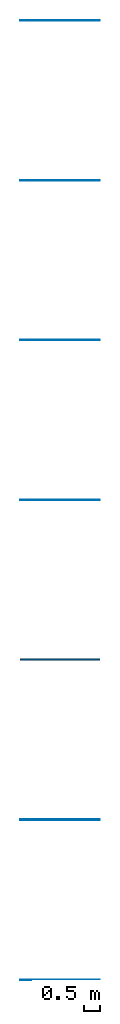
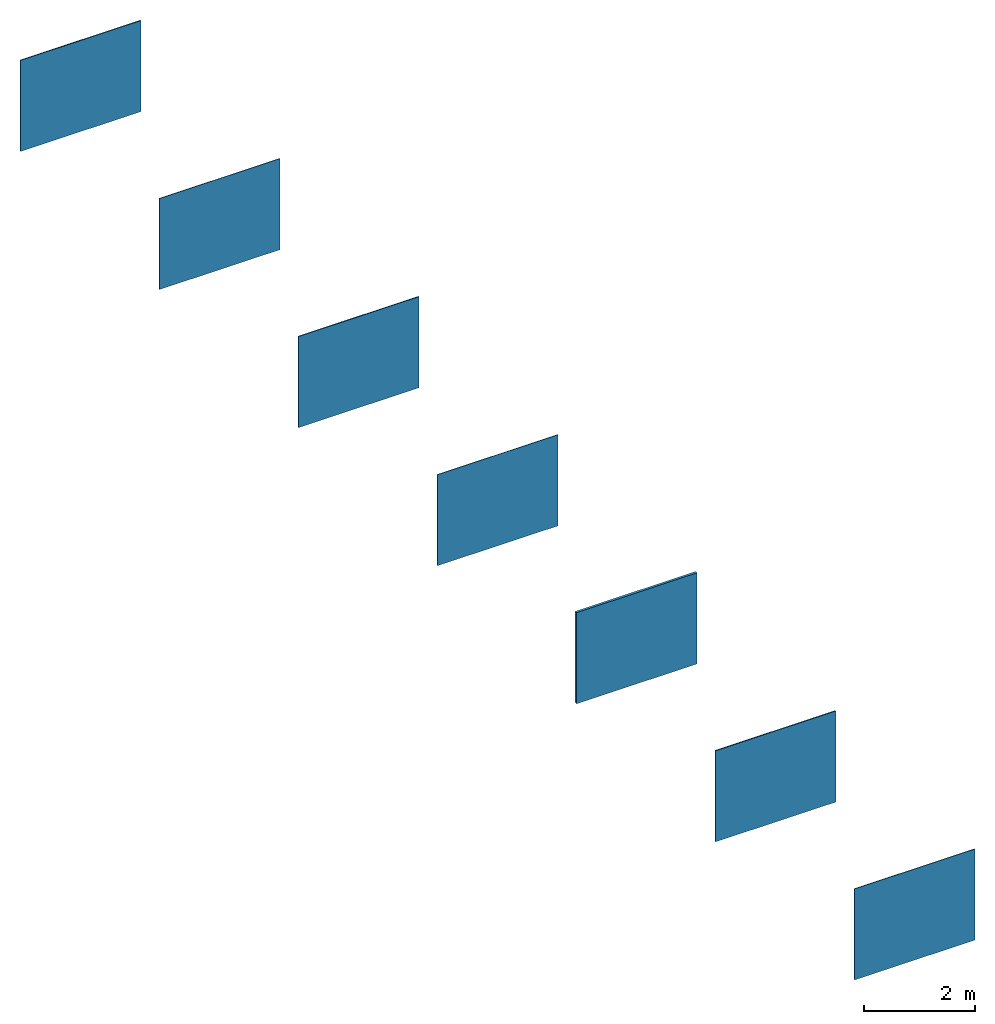
# Not in any storey: 7 walls.
"""IFC2X3 building model written with IfcOpenShell, lengths in millimetres."""

from ifc_helpers import new_model, si_unit, frame, frame_2d, origin, origin_with_axes, origin_2d, place, context, project, spatial, rectangle, extrude, material, layer, layer_set, layer_usage, type_object, element, save


model = new_model("IFC2X3")

# Units and contexts
model_context = context("Model", 3, precision=1e-05, world=origin())
plan_context = context("Plan", 2, precision=1e-05, world=origin_2d())
ifc_project = project(units=[si_unit("LENGTHUNIT", "METRE", prefix="MILLI"), si_unit("AREAUNIT", "SQUARE_METRE"), si_unit("VOLUMEUNIT", "CUBIC_METRE"), si_unit("SOLIDANGLEUNIT", "STERADIAN"), si_unit("PLANEANGLEUNIT", "RADIAN"), si_unit("MASSUNIT", "GRAM"), si_unit("TIMEUNIT", "SECOND"), si_unit("THERMODYNAMICTEMPERATUREUNIT", "DEGREE_CELSIUS"), si_unit("LUMINOUSINTENSITYUNIT", "LUMEN")], contexts=[model_context, plan_context])

# Site, building
site_placement = place(None, frame((0.0, 0.0, 0.0), z_axis=(0.0, 1.0, 0.0), x_axis=(0.0, 0.0, 1.0)))
site = spatial("IfcSite", under=ifc_project, at=site_placement, CompositionType="ELEMENT")
building_placement = place(site_placement, frame((0.0, 0.0, 0.0), z_axis=(0.0, 1.0, 0.0), x_axis=(0.0, 0.0, 1.0)))
building = spatial("IfcBuilding", under=site, at=building_placement, Name="Default building", CompositionType="ELEMENT")

# Walls
ifc_material_1 = material()
ifc_layer_1 = layer(ifc_material_1, 14.0, ventilated=False)
ifc_layer_set_1 = layer_set([ifc_layer_1])
ifc_layer_usage_1 = layer_usage(ifc_layer_set_1, "AXIS2", "POSITIVE", 0.0)
wall_type_1 = type_object("IfcWallType", PredefinedType="STANDARD", material=ifc_layer_set_1)
wall_1_placement = place(None, origin())
element("IfcWallStandardCase", 1, at=wall_1_placement, inside=building, type_object=wall_type_1, material=ifc_layer_usage_1, context=model_context, shape_type="SweptSolid", body=[
    extrude(rectangle(XDim=2500.0, YDim=14.0, at=frame_2d((1250.0, 7.0))), origin_with_axes(), (0.0, 0.0, 1.0), 2000.0),
])
ifc_material_2 = material()
ifc_layer_2 = layer(ifc_material_2, 21.5, ventilated=False)
ifc_layer_set_2 = layer_set([ifc_layer_2])
ifc_layer_usage_2 = layer_usage(ifc_layer_set_2, "AXIS2", "POSITIVE", 0.0)
wall_type_2 = type_object("IfcWallType", PredefinedType="STANDARD", material=ifc_layer_set_2)
wall_2_placement = place(None, frame((0.0, 5000.0, 0.0)))
element("IfcWallStandardCase", 2, at=wall_2_placement, inside=building, type_object=wall_type_2, material=ifc_layer_usage_2, context=model_context, shape_type="SweptSolid", body=[
    extrude(rectangle(XDim=2500.0, YDim=21.5, at=frame_2d((1250.0, 10.75))), origin_with_axes(), (0.0, 0.0, 1.0), 2000.0),
])
ifc_material_3 = material()
ifc_layer_3 = layer(ifc_material_3, 51.5, ventilated=False)
ifc_layer_set_3 = layer_set([ifc_layer_3])
ifc_layer_usage_3 = layer_usage(ifc_layer_set_3, "AXIS2", "POSITIVE", 0.0)
wall_type_3 = type_object("IfcWallType", PredefinedType="STANDARD", material=ifc_layer_set_3)
wall_3_placement = place(None, frame((0.0, 10000.0, 0.0)))
element("IfcWallStandardCase", 3, at=wall_3_placement, inside=building, type_object=wall_type_3, material=ifc_layer_usage_3, context=model_context, shape_type="SweptSolid", body=[
    extrude(rectangle(XDim=2500.0, YDim=51.5, at=frame_2d((1250.0, 25.75))), origin_with_axes(), (0.0, 0.0, 1.0), 2000.0),
])
ifc_material_4 = material()
ifc_layer_4 = layer(ifc_material_4, 12.5, ventilated=False)
ifc_layer_set_4 = layer_set([ifc_layer_4])
ifc_layer_usage_4 = layer_usage(ifc_layer_set_4, "AXIS2", "POSITIVE", 0.0)
wall_type_4 = type_object("IfcWallType", PredefinedType="STANDARD", material=ifc_layer_set_4)
wall_4_placement = place(None, frame((0.0, 15000.0, 0.0)))
element("IfcWallStandardCase", 4, at=wall_4_placement, inside=building, type_object=wall_type_4, material=ifc_layer_usage_4, context=model_context, shape_type="SweptSolid", body=[
    extrude(rectangle(XDim=2500.0, YDim=12.5, at=frame_2d((1250.0, 6.25))), origin_with_axes(), (0.0, 0.0, 1.0), 2000.0),
])
ifc_material_5 = material()
ifc_layer_5 = layer(ifc_material_5, 20.0, ventilated=False)
ifc_layer_set_5 = layer_set([ifc_layer_5])
ifc_layer_usage_5 = layer_usage(ifc_layer_set_5, "AXIS2", "POSITIVE", 0.0)
wall_type_5 = type_object("IfcWallType", PredefinedType="STANDARD", material=ifc_layer_set_5)
wall_5_placement = place(None, frame((0.0, 20000.0, 0.0)))
element("IfcWallStandardCase", 5, at=wall_5_placement, inside=building, type_object=wall_type_5, material=ifc_layer_usage_5, context=model_context, shape_type="SweptSolid", body=[
    extrude(rectangle(XDim=2500.0, YDim=20.0, at=frame_2d((1250.0, 10.0))), origin_with_axes(), (0.0, 0.0, 1.0), 2000.0),
])
ifc_material_6 = material()
ifc_layer_6 = layer(ifc_material_6, 12.5, ventilated=False)
ifc_layer_set_6 = layer_set([ifc_layer_6])
ifc_layer_usage_6 = layer_usage(ifc_layer_set_6, "AXIS2", "POSITIVE", 0.0)
wall_type_6 = type_object("IfcWallType", PredefinedType="STANDARD", material=ifc_layer_set_6)
wall_6_placement = place(None, frame((0.0, 25000.0, 0.0)))
element("IfcWallStandardCase", 6, at=wall_6_placement, inside=building, type_object=wall_type_6, material=ifc_layer_usage_6, context=model_context, shape_type="SweptSolid", body=[
    extrude(rectangle(XDim=2500.0, YDim=12.5, at=frame_2d((1250.0, 6.25))), origin_with_axes(), (0.0, 0.0, 1.0), 2000.0),
])
ifc_material_7 = material()
ifc_layer_7 = layer(ifc_material_7, 20.0, ventilated=False)
ifc_layer_set_7 = layer_set([ifc_layer_7])
ifc_layer_usage_7 = layer_usage(ifc_layer_set_7, "AXIS2", "POSITIVE", 0.0)
wall_type_7 = type_object("IfcWallType", PredefinedType="STANDARD", material=ifc_layer_set_7)
wall_7_placement = place(None, frame((0.0, 30000.0, 0.0)))
element("IfcWallStandardCase", 7, at=wall_7_placement, inside=building, type_object=wall_type_7, material=ifc_layer_usage_7, context=model_context, shape_type="SweptSolid", body=[
    extrude(rectangle(XDim=2500.0, YDim=20.0, at=frame_2d((1250.0, 10.0))), origin_with_axes(), (0.0, 0.0, 1.0), 2000.0),
])

save(model, "model.ifc")
